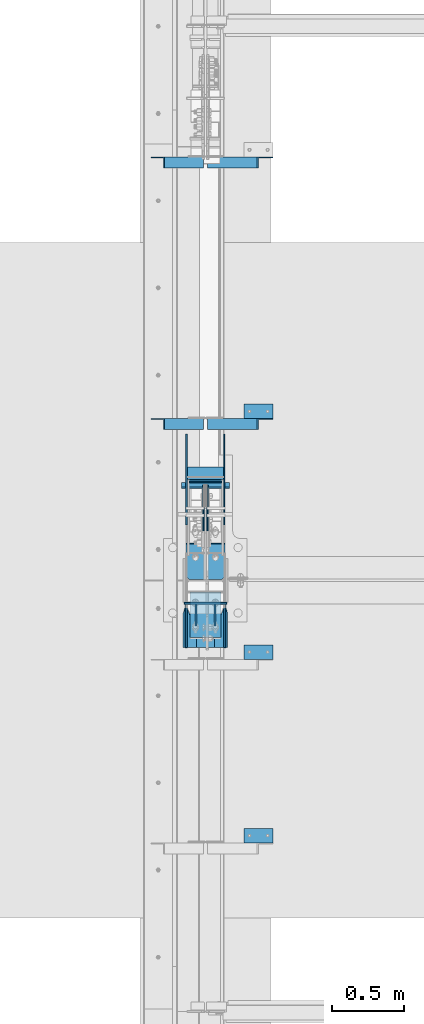
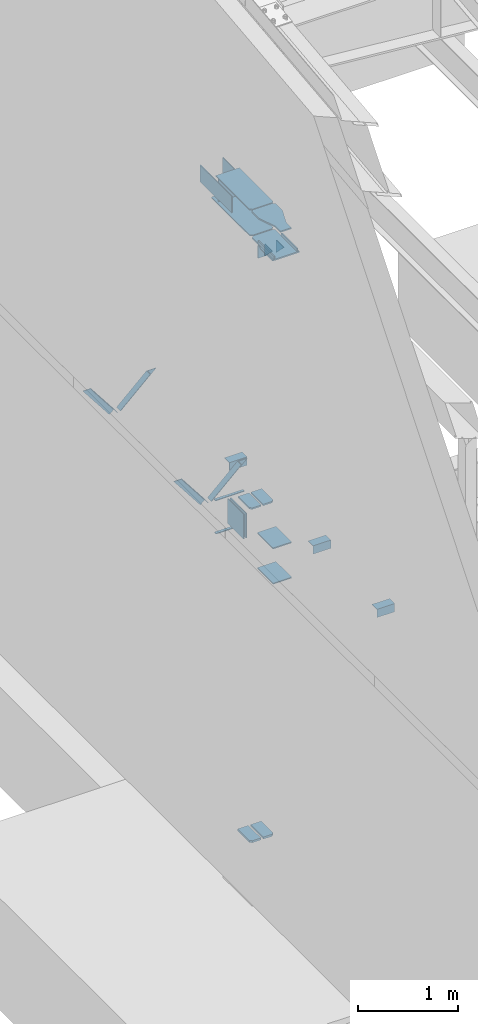
# One storey, part 811 of 1179: 25 beams, 4 members, 16 elements without a shape of their own.
"""IFC2X3 building model written with IfcOpenShell, lengths in millimetres."""

from ifc_helpers import new_model, si_unit, frame, origin_with_axes, place, context, subcontext, project, spatial, faceted_brep, material, type_object, element, aggregate, save


model = new_model("IFC2X3")

# Units and contexts
model_context = context("Model", 3, precision=1e-05, world=origin_with_axes())
body_context = subcontext(model_context, "Body", "Model", "MODEL_VIEW")
ifc_project = project(units=[si_unit("LENGTHUNIT", "METRE", prefix="MILLI"), si_unit("AREAUNIT", "SQUARE_METRE"), si_unit("VOLUMEUNIT", "CUBIC_METRE"), si_unit("MASSUNIT", "GRAM", prefix="KILO"), si_unit("TIMEUNIT", "SECOND"), si_unit("PLANEANGLEUNIT", "RADIAN"), si_unit("SOLIDANGLEUNIT", "STERADIAN"), si_unit("THERMODYNAMICTEMPERATUREUNIT", "DEGREE_CELSIUS"), si_unit("LUMINOUSINTENSITYUNIT", "LUMEN")], contexts=[model_context])

# Site, building, storey
site_placement = place(None, origin_with_axes())
site = spatial("IfcSite", under=ifc_project, at=site_placement, CompositionType="ELEMENT")
building_placement = place(site_placement, origin_with_axes())
building = spatial("IfcBuilding", under=site, at=building_placement, Name="Undefined", CompositionType="ELEMENT")
storey_placement = place(building_placement, origin_with_axes())
storey = spatial("IfcBuildingStorey", under=building, at=storey_placement, Name="Undefined", CompositionType="ELEMENT", Elevation=0.0)

# Assembly, member
assembly_1_placement = place(storey_placement, origin_with_axes())
assembly_1 = element("IfcElementAssembly", 1, at=assembly_1_placement, inside=storey, Name="ANGLE", AssemblyPlace="NOTDEFINED", PredefinedType="RIGID_FRAME")
ifc_material_1 = material(Name="STEEL/A36")
member_type = type_object("IfcMemberType", Name="L3X3X1/4", PredefinedType="NOTDEFINED")
member_1_placement = place(assembly_1_placement, frame((472.414639168564, 14401.8, 3736.19330123132), z_axis=(0.0, -1.0, 0.0), x_axis=(0.729484494811633, 0.0, 0.683997347823379)))
member_1 = element("IfcMember", 2, at=member_1_placement, type_object=member_type, material=ifc_material_1, Name="ANGLE", ObjectType="L3X3X1/4", context=body_context, shape_type="Brep", body=[
    faceted_brep([(0.0, 38.0999999999985, -38.0999999999999), (0.0, 38.0999999999985, 38.0999999999999), (475.752341075195, 38.0999999999181, 38.1000000000004), (475.752341075195, 38.0999999999181, -38.1000000000004), (0.0, 31.75, 38.1000000000004), (482.524628360803, 31.7499999999177, 38.1000000000004), (0.0, 31.75, -31.75), (482.524628360803, 31.7499999999177, -31.75), (0.0, -38.0999999999985, -31.75), (557.019788502486, -38.1000000000854, -31.75), (0.0, -38.0999999999985, -38.0999999999999), (557.019788502486, -38.1000000000854, -38.1000000000004)], [[[0, 1, 2, 3]], [[1, 4, 5, 2]], [[4, 6, 7, 5]], [[6, 8, 9, 7]], [[8, 10, 11, 9]], [[10, 0, 3, 11]], [[5, 7, 9, 11, 3, 2]], [[10, 8, 6, 4, 1, 0]]]),
])
aggregate(assembly_1, [member_1])

assembly_2_placement = place(storey_placement, origin_with_axes())
assembly_2 = element("IfcElementAssembly", 3, at=assembly_2_placement, inside=storey, Name="ANGLE", AssemblyPlace="NOTDEFINED", PredefinedType="RIGID_FRAME")
member_2_placement = place(assembly_2_placement, frame((472.414639168564, 12573.0, 3736.19330123132), z_axis=(0.0, -1.0, 0.0), x_axis=(0.729484494811633, 0.0, 0.683997347823379)))
member_2 = element("IfcMember", 4, at=member_2_placement, type_object=member_type, material=ifc_material_1, Name="ANGLE", ObjectType="L3X3X1/4", context=body_context, shape_type="Brep", body=[
    faceted_brep([(0.0, 38.0999999999985, -38.0999999999999), (0.0, 38.0999999999985, 38.0999999999999), (475.752341075195, 38.0999999999181, 38.1000000000004), (475.752341075195, 38.0999999999181, -38.1000000000004), (0.0, 31.75, 38.1000000000004), (482.524628360803, 31.7499999999177, 38.1000000000004), (0.0, 31.75, -31.75), (482.524628360803, 31.7499999999177, -31.75), (0.0, -38.0999999999985, -31.75), (557.019788502486, -38.1000000000854, -31.75), (0.0, -38.0999999999985, -38.0999999999999), (557.019788502486, -38.1000000000854, -38.1000000000004)], [[[0, 1, 2, 3]], [[1, 4, 5, 2]], [[4, 6, 7, 5]], [[6, 8, 9, 7]], [[8, 10, 11, 9]], [[10, 0, 3, 11]], [[5, 7, 9, 11, 3, 2]], [[10, 8, 6, 4, 1, 0]]]),
])
aggregate(assembly_2, [member_2])

assembly_3_placement = place(storey_placement, origin_with_axes())
assembly_3 = element("IfcElementAssembly", 5, at=assembly_3_placement, inside=storey, Name="ANGLE", AssemblyPlace="NOTDEFINED", PredefinedType="RIGID_FRAME")
member_3_placement = place(assembly_3_placement, frame((80.8196258456476, 14401.8, 4125.56128839178), z_axis=(0.0, -1.0, 0.0), x_axis=(0.614083067285056, 0.0, -0.789241399366364)))
member_3 = element("IfcMember", 6, at=member_3_placement, type_object=member_type, material=ifc_material_1, Name="ANGLE", ObjectType="L3X3X1/4", context=body_context, shape_type="Brep", body=[
    faceted_brep([(59.3707492954454, 38.0999999999781, -38.1000000000004), (59.3707492954454, 38.0999999999781, 38.1000000000004), (499.083854779058, 38.0999999998585, 38.1000000000004), (499.083854779058, 38.0999999998585, -38.1000000000004), (54.4300207928691, 31.7499999999804, 38.1000000000004), (499.083854779056, 31.7499999998595, 38.1000000000004), (54.4300207928691, 31.7499999999804, -31.75), (499.083854779056, 31.7499999998595, -31.75), (0.0820072645328764, -38.0999999999945, -31.75), (499.083854779043, -38.10000000013, -31.75), (0.0820072645328764, -38.0999999999945, -38.1000000000004), (499.083854779043, -38.10000000013, -38.1000000000004)], [[[0, 1, 2, 3]], [[1, 4, 5, 2]], [[4, 6, 7, 5]], [[6, 8, 9, 7]], [[8, 10, 11, 9]], [[10, 0, 3, 11]], [[5, 7, 9, 11, 3, 2]], [[10, 8, 6, 4, 1, 0]]]),
])
aggregate(assembly_3, [member_3])

assembly_4_placement = place(storey_placement, origin_with_axes())
assembly_4 = element("IfcElementAssembly", 7, at=assembly_4_placement, inside=storey, Name="ANGLE", AssemblyPlace="NOTDEFINED", PredefinedType="RIGID_FRAME")
member_4_placement = place(assembly_4_placement, frame((80.8196258456476, 12573.0, 4125.56128839178), z_axis=(0.0, -1.0, 0.0), x_axis=(0.614083067285056, 0.0, -0.789241399366364)))
member_4 = element("IfcMember", 8, at=member_4_placement, type_object=member_type, material=ifc_material_1, Name="ANGLE", ObjectType="L3X3X1/4", context=body_context, shape_type="Brep", body=[
    faceted_brep([(59.3707492954454, 38.0999999999781, -38.1000000000004), (59.3707492954454, 38.0999999999781, 38.1000000000004), (499.083854779058, 38.0999999998585, 38.1000000000004), (499.083854779058, 38.0999999998585, -38.1000000000004), (54.4300207928691, 31.7499999999804, 38.1000000000004), (499.083854779056, 31.7499999998595, 38.1000000000004), (54.4300207928691, 31.7499999999804, -31.75), (499.083854779056, 31.7499999998595, -31.75), (0.0820072645328764, -38.0999999999945, -31.75), (499.083854779043, -38.10000000013, -31.75), (0.0820072645328764, -38.0999999999945, -38.1000000000004), (499.083854779043, -38.10000000013, -38.1000000000004)], [[[0, 1, 2, 3]], [[1, 4, 5, 2]], [[4, 6, 7, 5]], [[6, 8, 9, 7]], [[8, 10, 11, 9]], [[10, 0, 3, 11]], [[5, 7, 9, 11, 3, 2]], [[10, 8, 6, 4, 1, 0]]]),
])
aggregate(assembly_4, [member_4])

# Assembly, beams
assembly_5_placement = place(storey_placement, origin_with_axes())
assembly_5 = element("IfcElementAssembly", 9, at=assembly_5_placement, inside=storey, Name="BEAM", AssemblyPlace="NOTDEFINED", PredefinedType="RIGID_FRAME")
ifc_material_2 = material(Name="STEEL/A572-GR.50")
beam_type_1 = type_object("IfcBeamType", PredefinedType="NOTDEFINED")
beam_1_placement = place(assembly_5_placement, frame((431.800036620873, 12122.4863327342, 3678.2375), z_axis=(-1.0, 0.0, 0.0), x_axis=(0.0, 1.0, 0.0)))
beam_1 = element("IfcBeam", 10, at=beam_1_placement, type_object=beam_type_1, material=ifc_material_2, Name="PLATE", context=body_context, shape_type="Brep", body=[
    faceted_brep([(0.0, 4.76249999999982, -168.275000000001), (0.0, 4.76250000000073, 168.275), (31.75, 4.76249999999982, 168.275000000001), (31.75, 4.76249999999982, -168.275000000001), (0.0, -4.76250000000073, 168.275), (31.75, -4.76249999999982, 168.275000000001), (0.0, -4.76249999999982, -168.275000000001), (31.75, -4.76249999999982, -168.275000000001)], [[[0, 1, 2, 3]], [[1, 4, 5, 2]], [[4, 6, 7, 5]], [[6, 0, 3, 7]], [[5, 7, 3, 2]], [[6, 4, 1, 0]]]),
])
beam_2_placement = place(assembly_5_placement, frame((431.800036620873, 12133.5984303375, 4077.8905), z_axis=(-1.0, 0.0, 0.0), x_axis=(0.0, 1.0, 0.0)))
beam_2 = element("IfcBeam", 11, at=beam_2_placement, type_object=beam_type_1, material=ifc_material_2, Name="PLATE", context=body_context, shape_type="Brep", body=[
    faceted_brep([(0.0, 4.76249999999982, -168.275000000001), (0.0, 4.76250000000073, 168.275), (31.75, 4.76249999999982, 168.275000000001), (31.75, 4.76249999999982, -168.275000000001), (0.0, -4.76250000000073, 168.275), (31.75, -4.76249999999982, 168.275000000001), (0.0, -4.76249999999982, -168.275000000001), (31.75, -4.76249999999982, -168.275000000001)], [[[0, 1, 2, 3]], [[1, 4, 5, 2]], [[4, 6, 7, 5]], [[6, 0, 3, 7]], [[5, 7, 3, 2]], [[6, 4, 1, 0]]]),
])
aggregate(assembly_5, [beam_1, beam_2])

assembly_6_placement = place(storey_placement, origin_with_axes())
assembly_6 = element("IfcElementAssembly", 12, at=assembly_6_placement, inside=storey, Name="COLUMN", AssemblyPlace="NOTDEFINED", PredefinedType="RIGID_FRAME")
beam_type_2 = type_object("IfcBeamType", PredefinedType="NOTDEFINED")
beam_3_placement = place(assembly_6_placement, frame((284.162500000006, 11320.4625, 7616.82500000912), z_axis=(0.0, 0.0, 1.0), x_axis=(1.0, 0.0, 0.0)))
beam_3 = element("IfcBeam", 13, at=beam_3_placement, type_object=beam_type_2, material=ifc_material_1, Name="PLATE", context=body_context, shape_type="Brep", body=[
    faceted_brep([(-7.27595761418343e-12, 6.35000000000036, -76.1999999999971), (0.0, 6.35000000000036, 76.2000000000044), (295.274999999994, 6.34999999999854, 76.2000000000007), (295.274999999994, 6.34999999999854, -76.2000000000007), (0.0, -6.35000000000036, 76.2000000000044), (295.274999999994, -6.34999999999854, 76.2000000000007), (7.27595761418343e-12, -6.35000000000036, -76.1999999999971), (295.274999999994, -6.34999999999854, -76.2000000000007)], [[[0, 1, 2, 3]], [[1, 4, 5, 2]], [[4, 6, 7, 5]], [[6, 0, 3, 7]], [[5, 7, 3, 2]], [[6, 4, 1, 0]]]),
])
beam_type_3 = type_object("IfcBeamType", PredefinedType="NOTDEFINED")
beam_4_placement = place(assembly_6_placement, frame((505.619000000002, 11734.5860983541, 4353.49928057188), z_axis=(1.0, 0.0, 0.0), x_axis=(0.0, -1.0, 0.0)))
beam_4 = element("IfcBeam", 14, at=beam_4_placement, type_object=beam_type_3, material=ifc_material_2, Name="PLATE", context=body_context, shape_type="Brep", body=[
    faceted_brep([(247.436098354521, -9.52499999999964, 40.4809996181785), (247.436098354145, 9.52499999999964, 40.4809996181785), (225.211098339509, 9.52499999999964, 62.7065000000002), (225.211098339509, -9.52499999999964, 62.7065000000002), (6.18456397205591e-11, -9.52499999999964, -62.7065000000084), (0.0, -9.52499999999964, 62.7065000000002), (0.0, 9.52499999999964, 62.7065000000002), (6.18456397205591e-11, 9.52499999999964, -62.7065000000084), (247.436098339509, 9.52499999999964, -62.7065000000002), (247.436098339509, -9.52499999999964, -62.7065000000002)], [[[0, 1, 2, 3]], [[4, 5, 6, 7]], [[4, 7, 8, 9]], [[5, 4, 9, 0, 3]], [[6, 5, 3, 2]], [[8, 7, 6, 2, 1]], [[9, 8, 1, 0]]]),
])
beam_5_placement = place(assembly_6_placement, frame((357.981000000002, 11734.5860983541, 4353.49928057188), z_axis=(-1.0, 0.0, 0.0), x_axis=(0.0, -1.0, 0.0)))
beam_5 = element("IfcBeam", 15, at=beam_5_placement, type_object=beam_type_3, material=ifc_material_2, Name="PLATE", context=body_context, shape_type="Brep", body=[
    faceted_brep([(247.436098354521, -9.52499999999964, 40.4809996181785), (247.436098354145, 9.52499999999964, 40.4809996181785), (225.211098339509, 9.52499999999964, 62.7065000000002), (225.211098339509, -9.52499999999964, 62.7065000000002), (6.18456397205591e-11, -9.52499999999964, -62.7065000000084), (0.0, -9.52499999999964, 62.7065000000002), (0.0, 9.52499999999964, 62.7065000000002), (6.18456397205591e-11, 9.52499999999964, -62.7065000000084), (247.436098339509, 9.52499999999964, -62.7065000000002), (247.436098339509, -9.52499999999964, -62.7065000000002)], [[[0, 1, 2, 3]], [[4, 5, 6, 7]], [[4, 7, 8, 9]], [[5, 4, 9, 0, 3]], [[6, 5, 3, 2]], [[8, 7, 6, 2, 1]], [[9, 8, 1, 0]]]),
])
beam_type_4 = type_object("IfcBeamType", PredefinedType="NOTDEFINED")
beam_6_placement = place(assembly_6_placement, frame((431.800000000002, 11398.2499999514, 3676.64999999946), z_axis=(-1.0, 0.0, 0.0), x_axis=(0.0, -1.0, 0.0)))
beam_6 = element("IfcBeam", 16, at=beam_6_placement, type_object=beam_type_4, material=ifc_material_2, Name="PLATE", context=body_context, shape_type="Brep", body=[
    faceted_brep([(0.0, 6.35000000000036, -107.949999999997), (0.0, 6.35000000000036, 107.949999999997), (317.5, 6.35000000000036, 107.949999999997), (317.5, 6.35000000000036, -107.949999999997), (0.0, -6.35000000000036, 107.949999999997), (317.5, -6.35000000000036, 107.949999999997), (0.0, -6.35000000000036, -107.949999999997), (317.5, -6.35000000000036, -107.949999999997)], [[[0, 1, 2, 3]], [[1, 4, 5, 2]], [[4, 6, 7, 5]], [[6, 0, 3, 7]], [[5, 7, 3, 2]], [[6, 4, 1, 0]]]),
])
beam_7_placement = place(assembly_6_placement, frame((431.800000000002, 11398.2499999514, 4108.44999999946), z_axis=(-1.0, 0.0, 0.0), x_axis=(0.0, -1.0, 0.0)))
beam_7 = element("IfcBeam", 17, at=beam_7_placement, type_object=beam_type_4, material=ifc_material_2, Name="PLATE", context=body_context, shape_type="Brep", body=[
    faceted_brep([(0.0, 6.35000000000036, -107.949999999997), (0.0, 6.35000000000036, 107.949999999997), (317.5, 6.35000000000036, 107.949999999997), (317.5, 6.35000000000036, -107.949999999997), (0.0, -6.35000000000036, 107.949999999997), (317.5, -6.35000000000036, 107.949999999997), (0.0, -6.35000000000036, -107.949999999997), (317.5, -6.35000000000036, -107.949999999997)], [[[0, 1, 2, 3]], [[1, 4, 5, 2]], [[4, 6, 7, 5]], [[6, 0, 3, 7]], [[5, 7, 3, 2]], [[6, 4, 1, 0]]]),
])

# Assembly, beam
assembly_7_placement = place(storey_placement, origin_with_axes())
assembly_7 = element("IfcElementAssembly", 18, at=assembly_7_placement, inside=storey, Name="ANGLE", AssemblyPlace="NOTDEFINED", PredefinedType="RIGID_FRAME")
beam_type_5 = type_object("IfcBeamType", Name="L4X4X1/4", PredefinedType="NOTDEFINED")
beam_8_placement = place(assembly_7_placement, frame((701.59635534156, 10979.15, 4051.3), z_axis=(0.0, 0.0, -1.0), x_axis=(1.0, 0.0, 0.0)))
beam_8 = element("IfcBeam", 19, at=beam_8_placement, type_object=beam_type_5, material=ifc_material_1, Name="ANGLE", ObjectType="L4X4X1/4", context=body_context, shape_type="Brep", body=[
    faceted_brep([(1.90993887372315e-11, 50.8000000000002, -50.8000000000002), (1.90993887372315e-11, 50.8000000000002, 50.8000000000002), (203.200000000001, 50.7999999999993, 50.8000000000002), (203.200000000001, 50.7999999999993, -50.8000000000002), (0.0, 44.4500000000007, 50.8000000000002), (203.200000000001, 44.4500000000007, 50.8000000000002), (0.0, 44.4500000000007, -44.4499999999998), (203.200000000001, 44.4500000000007, -44.4499999999998), (0.0, -50.7999999999993, -44.4499999999998), (203.200000000001, -50.7999999999993, -44.4499999999998), (-1.81898940354586e-11, -50.7999999999997, -50.8000000000002), (203.200000000001, -50.7999999999993, -50.8000000000002)], [[[0, 1, 2, 3]], [[1, 4, 5, 2]], [[4, 6, 7, 5]], [[6, 8, 9, 7]], [[8, 10, 11, 9]], [[10, 0, 3, 11]], [[5, 7, 9, 11, 3, 2]], [[10, 8, 6, 4, 1, 0]]]),
])
aggregate(assembly_7, [beam_8])

assembly_8_placement = place(storey_placement, origin_with_axes())
assembly_8 = element("IfcElementAssembly", 20, at=assembly_8_placement, inside=storey, Name="ANGLE", AssemblyPlace="NOTDEFINED", PredefinedType="RIGID_FRAME")
beam_9_placement = place(assembly_8_placement, frame((701.59635534156, 9695.65999128227, 4051.3), z_axis=(0.0, 0.0, -1.0), x_axis=(1.0, 0.0, 0.0)))
beam_9 = element("IfcBeam", 21, at=beam_9_placement, type_object=beam_type_5, material=ifc_material_1, Name="ANGLE", ObjectType="L4X4X1/4", context=body_context, shape_type="Brep", body=[
    faceted_brep([(1.90993887372315e-11, 50.8000000000002, -50.8000000000002), (1.90993887372315e-11, 50.8000000000002, 50.8000000000002), (203.200000000001, 50.7999999999993, 50.8000000000002), (203.200000000001, 50.7999999999993, -50.8000000000002), (0.0, 44.4500000000007, 50.8000000000002), (203.200000000001, 44.4500000000007, 50.8000000000002), (0.0, 44.4500000000007, -44.4499999999998), (203.200000000001, 44.4500000000007, -44.4499999999998), (0.0, -50.7999999999993, -44.4499999999998), (203.200000000001, -50.7999999999993, -44.4499999999998), (-1.81898940354586e-11, -50.7999999999997, -50.8000000000002), (203.200000000001, -50.7999999999993, -50.8000000000002)], [[[0, 1, 2, 3]], [[1, 4, 5, 2]], [[4, 6, 7, 5]], [[6, 8, 9, 7]], [[8, 10, 11, 9]], [[10, 0, 3, 11]], [[5, 7, 9, 11, 3, 2]], [[10, 8, 6, 4, 1, 0]]]),
])
aggregate(assembly_8, [beam_9])

assembly_9_placement = place(storey_placement, origin_with_axes())
assembly_9 = element("IfcElementAssembly", 22, at=assembly_9_placement, inside=storey, Name="ANGLE", AssemblyPlace="NOTDEFINED", PredefinedType="RIGID_FRAME")
beam_10_placement = place(assembly_9_placement, frame((701.596355341562, 12661.9, 4051.3), z_axis=(0.0, 0.0, -1.0), x_axis=(1.0, 0.0, 0.0)))
beam_10 = element("IfcBeam", 23, at=beam_10_placement, type_object=beam_type_5, material=ifc_material_1, Name="ANGLE", ObjectType="L4X4X1/4", context=body_context, shape_type="Brep", body=[
    faceted_brep([(1.90993887372315e-11, 50.8000000000002, -50.8000000000002), (1.90993887372315e-11, 50.8000000000002, 50.8000000000002), (203.200000000001, 50.7999999999993, 50.8000000000002), (203.200000000001, 50.7999999999993, -50.8000000000002), (0.0, 44.4500000000007, 50.8000000000002), (203.200000000001, 44.4500000000007, 50.8000000000002), (0.0, 44.4500000000007, -44.4499999999998), (203.200000000001, 44.4500000000007, -44.4499999999998), (0.0, -50.7999999999993, -44.4499999999998), (203.200000000001, -50.7999999999993, -44.4499999999998), (-1.81898940354586e-11, -50.7999999999997, -50.8000000000002), (203.200000000001, -50.7999999999993, -50.8000000000002)], [[[0, 1, 2, 3]], [[1, 4, 5, 2]], [[4, 6, 7, 5]], [[6, 8, 9, 7]], [[8, 10, 11, 9]], [[10, 0, 3, 11]], [[5, 7, 9, 11, 3, 2]], [[10, 8, 6, 4, 1, 0]]]),
])
aggregate(assembly_9, [beam_10])

assembly_10_placement = place(storey_placement, origin_with_axes())
assembly_10 = element("IfcElementAssembly", 24, at=assembly_10_placement, inside=storey, Name="PLATE", AssemblyPlace="NOTDEFINED", PredefinedType="RIGID_FRAME")
beam_type_6 = type_object("IfcBeamType", PredefinedType="NOTDEFINED")
beam_11_placement = place(assembly_10_placement, frame((563.562500000004, 11867.9751974615, 7861.3), z_axis=(0.0, 0.0, 1.0), x_axis=(0.0, 1.0, 0.0)))
beam_11 = element("IfcBeam", 25, at=beam_11_placement, type_object=beam_type_6, material=ifc_material_2, Name="PLATE", context=body_context, shape_type="Brep", body=[
    faceted_brep([(0.0, 4.76250000000073, -101.6), (0.0, 4.76250000000073, 101.6), (635.0, 4.76250000000073, 101.6), (635.0, 4.76250000000073, -101.6), (0.0, -4.76250000000073, 101.6), (635.0, -4.76250000000073, 101.6), (0.0, -4.76250000000073, -101.6), (635.0, -4.76250000000073, -101.6)], [[[0, 1, 2, 3]], [[1, 4, 5, 2]], [[4, 6, 7, 5]], [[6, 0, 3, 7]], [[5, 7, 3, 2]], [[6, 4, 1, 0]]]),
])
aggregate(assembly_10, [beam_11])

assembly_11_placement = place(storey_placement, origin_with_axes())
assembly_11 = element("IfcElementAssembly", 26, at=assembly_11_placement, inside=storey, Name="PLATE", AssemblyPlace="NOTDEFINED", PredefinedType="RIGID_FRAME")
beam_12_placement = place(assembly_11_placement, frame((300.037500000002, 11867.9751974615, 7861.3), z_axis=(0.0, 0.0, 1.0), x_axis=(0.0, 1.0, 0.0)))
beam_12 = element("IfcBeam", 27, at=beam_12_placement, type_object=beam_type_6, material=ifc_material_2, Name="PLATE", context=body_context, shape_type="Brep", body=[
    faceted_brep([(0.0, 4.76250000000073, -101.6), (0.0, 4.76250000000073, 101.6), (635.0, 4.76250000000073, 101.6), (635.0, 4.76250000000073, -101.6), (0.0, -4.76250000000073, 101.6), (635.0, -4.76250000000073, 101.6), (0.0, -4.76250000000073, -101.6), (635.0, -4.76250000000073, -101.6)], [[[0, 1, 2, 3]], [[1, 4, 5, 2]], [[4, 6, 7, 5]], [[6, 0, 3, 7]], [[5, 7, 3, 2]], [[6, 4, 1, 0]]]),
])
aggregate(assembly_11, [beam_12])

# Beam
beam_type_7 = type_object("IfcBeamType", PredefinedType="NOTDEFINED")
beam_13_placement = place(assembly_6_placement, frame((317.5, 12168.0126974615, 7861.3), z_axis=(0.0, 0.0, 1.0), x_axis=(1.0, 0.0, 0.0)))
beam_13 = element("IfcBeam", 28, at=beam_13_placement, type_object=beam_type_7, material=ifc_material_2, Name="PLATE", context=body_context, shape_type="Brep", body=[
    faceted_brep([(0.0, 4.76250000000073, -152.4), (0.0, 4.76250000000073, 152.4), (228.600000000002, 4.76250000000073, 152.4), (228.600000000002, 4.76250000000073, -152.4), (0.0, -4.76250000000073, 152.4), (228.600000000002, -4.76250000000073, 152.4), (0.0, -4.76250000000073, -152.4), (228.600000000002, -4.76250000000073, -152.4)], [[[0, 1, 2, 3]], [[1, 4, 5, 2]], [[4, 6, 7, 5]], [[6, 0, 3, 7]], [[5, 7, 3, 2]], [[6, 4, 1, 0]]]),
])

beam_type_8 = type_object("IfcBeamType", PredefinedType="NOTDEFINED")
beam_14_placement = place(assembly_6_placement, frame((431.799999999999, 12274.3751974615, 7702.55), z_axis=(-1.0, 0.0, 0.0), x_axis=(0.0, -1.0, 0.0)))
beam_14 = element("IfcBeam", 29, at=beam_14_placement, type_object=beam_type_8, material=ifc_material_2, Name="PLATE", context=body_context, shape_type="Brep", body=[
    faceted_brep([(765.000197461464, 6.35000000000036, -136.525000000001), (787.225197461465, 6.35000000000036, -114.299999999999), (787.225197461465, -6.35000000000036, -114.299999999999), (765.000197461464, -6.35000000000036, -136.525000000001), (787.225197461465, 6.35000000000036, 114.299999999999), (765.000197461464, 6.35000000000036, 136.525000000001), (765.000197461464, -6.35000000000036, 136.525000000001), (787.225197461465, -6.35000000000036, 114.299999999999), (0.0, 6.35000000000036, -136.525000000001), (0.0, 6.35000000000036, 136.525000000001), (0.0, -6.35000000000036, 136.525000000001), (0.0, -6.35000000000036, -136.525000000001)], [[[0, 1, 2, 3]], [[4, 5, 6, 7]], [[8, 9, 5, 4, 1, 0]], [[9, 10, 6, 5]], [[7, 6, 10, 11, 3, 2]], [[11, 8, 0, 3]], [[4, 7, 2, 1]], [[11, 10, 9, 8]]]),
])

beam_15_placement = place(assembly_6_placement, frame((431.799999999999, 12185.4751974615, 8020.05), z_axis=(-1.0, 0.0, 0.0), x_axis=(0.0, -1.0, 0.0)))
beam_15 = element("IfcBeam", 30, at=beam_15_placement, type_object=beam_type_8, material=ifc_material_2, Name="PLATE", context=body_context, shape_type="Brep", body=[
    faceted_brep([(676.100197461472, 6.35000000000036, -136.525000000001), (698.325197461472, 6.35000000000036, -114.299999999999), (698.325197461472, -6.35000000000036, -114.299999999999), (676.100197461472, -6.35000000000036, -136.525000000001), (698.325197461472, 6.35000000000036, 114.299999999999), (676.100197461472, 6.35000000000036, 136.525000000001), (676.100197461472, -6.35000000000036, 136.525000000001), (698.325197461472, -6.35000000000036, 114.299999999999), (0.0, 6.35000000000036, -136.525000000001), (0.0, 6.35000000000036, 136.525000000001), (0.0, -6.35000000000036, 136.525000000001), (0.0, -6.35000000000036, -136.525000000001)], [[[0, 1, 2, 3]], [[4, 5, 6, 7]], [[8, 9, 5, 4, 1, 0]], [[9, 10, 6, 5]], [[7, 6, 10, 11, 3, 2]], [[11, 8, 0, 3]], [[4, 7, 2, 1]], [[11, 10, 9, 8]]]),
])

# Assembly, beam
assembly_12_placement = place(storey_placement, origin_with_axes())
assembly_12 = element("IfcElementAssembly", 31, at=assembly_12_placement, inside=storey, Name="PLATE", AssemblyPlace="NOTDEFINED", PredefinedType="RIGID_FRAME")
beam_type_9 = type_object("IfcBeamType", PredefinedType="NOTDEFINED")
beam_16_placement = place(assembly_12_placement, frame((356.3935, 11742.2619188609, 267.318748335632), z_axis=(-1.0, 0.0, 0.0), x_axis=(0.0, -1.0, 0.0)))
beam_16 = element("IfcBeam", 32, at=beam_16_placement, type_object=beam_type_9, material=ifc_material_2, Name="PLATE", context=body_context, shape_type="Brep", body=[
    faceted_brep([(255.111918860846, 12.7, 38.8940000000002), (232.886918860846, 12.7, 61.1189999999988), (232.886918860846, -12.7, 61.1189999999988), (255.111918860846, -12.7, 38.8940000000002), (255.111918860846, 12.7, -61.1189999999988), (0.0, 12.7, -61.1189999999988), (0.0, 12.7, 61.1189999999988), (0.0, -12.7, 61.1189999999988), (0.0, -12.7, -61.1189999999988), (255.111918860846, -12.7, -61.1189999999988)], [[[0, 1, 2, 3]], [[4, 5, 6, 1, 0]], [[6, 7, 2, 1]], [[7, 8, 9, 3, 2]], [[8, 5, 4, 9]], [[9, 4, 0, 3]], [[8, 7, 6, 5]]]),
])
aggregate(assembly_12, [beam_16])

assembly_13_placement = place(storey_placement, origin_with_axes())
assembly_13 = element("IfcElementAssembly", 33, at=assembly_13_placement, inside=storey, Name="PLATE", AssemblyPlace="NOTDEFINED", PredefinedType="RIGID_FRAME")
beam_17_placement = place(assembly_13_placement, frame((507.2065, 11742.2619188609, 267.318748335632), z_axis=(1.0, 0.0, 0.0), x_axis=(0.0, -1.0, 0.0)))
beam_17 = element("IfcBeam", 34, at=beam_17_placement, type_object=beam_type_9, material=ifc_material_2, Name="PLATE", context=body_context, shape_type="Brep", body=[
    faceted_brep([(255.111918860846, 12.7, 38.8940000000002), (232.886918860846, 12.7, 61.1189999999988), (232.886918860846, -12.7, 61.1189999999988), (255.111918860846, -12.7, 38.8940000000002), (255.111918860846, 12.7, -61.1189999999988), (0.0, 12.7, -61.1189999999988), (0.0, 12.7, 61.1189999999988), (0.0, -12.7, 61.1189999999988), (0.0, -12.7, -61.1189999999988), (255.111918860846, -12.7, -61.1189999999988)], [[[0, 1, 2, 3]], [[4, 5, 6, 1, 0]], [[6, 7, 2, 1]], [[7, 8, 9, 3, 2]], [[8, 5, 4, 9]], [[9, 4, 0, 3]], [[8, 7, 6, 5]]]),
])
aggregate(assembly_13, [beam_17])

assembly_14_placement = place(storey_placement, origin_with_axes())
assembly_14 = element("IfcElementAssembly", 35, at=assembly_14_placement, inside=storey, Name="PLATE", AssemblyPlace="NOTDEFINED", PredefinedType="RIGID_FRAME")
beam_type_10 = type_object("IfcBeamType", PredefinedType="NOTDEFINED")
beam_18_placement = place(assembly_14_placement, frame((417.512500000002, 12146.2991796213, 3892.55), z_axis=(0.0, 0.0, -1.0), x_axis=(0.0, -1.0, 0.0)))
beam_18 = element("IfcBeam", 36, at=beam_18_placement, type_object=beam_type_10, material=ifc_material_2, Name="PLATE", context=body_context, shape_type="Brep", body=[
    faceted_brep([(0.0, 4.76250000000073, -152.4), (0.0, 4.76250000000073, 152.4), (317.5, 4.76250000000073, 152.4), (317.5, 4.76250000000073, -152.4), (0.0, -4.76250000000073, 152.4), (317.5, -4.76250000000073, 152.4), (0.0, -4.76250000000073, -152.4), (317.5, -4.76250000000073, -152.4)], [[[0, 1, 2, 3]], [[1, 4, 5, 2]], [[4, 6, 7, 5]], [[6, 0, 3, 7]], [[5, 7, 3, 2]], [[6, 4, 1, 0]]]),
])
aggregate(assembly_14, [beam_18])

assembly_15_placement = place(storey_placement, origin_with_axes())
assembly_15 = element("IfcElementAssembly", 37, at=assembly_15_placement, inside=storey, Name="PLATE", AssemblyPlace="NOTDEFINED", PredefinedType="RIGID_FRAME")
beam_19_placement = place(assembly_15_placement, frame((446.087213611823, 11828.7991796213, 3892.55), z_axis=(0.0, 0.0, -1.0), x_axis=(0.0, 1.0, 0.0)))
beam_19 = element("IfcBeam", 38, at=beam_19_placement, type_object=beam_type_10, material=ifc_material_2, Name="PLATE", context=body_context, shape_type="Brep", body=[
    faceted_brep([(0.0, 4.76250000000073, -152.4), (0.0, 4.76250000000073, 152.4), (317.5, 4.76250000000073, 152.4), (317.5, 4.76250000000073, -152.4), (0.0, -4.76250000000073, 152.4), (317.5, -4.76250000000073, 152.4), (0.0, -4.76250000000073, -152.4), (317.5, -4.76250000000073, -152.4)], [[[0, 1, 2, 3]], [[1, 4, 5, 2]], [[4, 6, 7, 5]], [[6, 0, 3, 7]], [[5, 7, 3, 2]], [[6, 4, 1, 0]]]),
])
aggregate(assembly_15, [beam_19])

# Beam
beam_type_11 = type_object("IfcBeamType", PredefinedType="NOTDEFINED")
beam_20_placement = place(assembly_6_placement, frame((296.862500000007, 11009.3125, 7727.95000000912), z_axis=(0.0, 0.0, 1.0), x_axis=(0.0, 1.0, 0.0)))
beam_20 = element("IfcBeam", 39, at=beam_20_placement, type_object=beam_type_11, material=ifc_material_1, Name="PLATE", context=body_context, shape_type="Brep", body=[
    faceted_brep([(0.0, 6.34999999999854, -19.0499999999993), (0.0, 6.35000000000036, 19.0499999999993), (317.5, 6.34999999999854, 19.0499999999993), (317.5, 6.34999999999854, -19.0499999999993), (0.0, -6.35000000000036, 19.0499999999993), (317.5, -6.34999999999854, 19.0499999999993), (0.0, -6.34999999999854, -19.0499999999993), (317.5, -6.34999999999854, -19.0499999999993)], [[[0, 1, 2, 3]], [[1, 4, 5, 2]], [[4, 6, 7, 5]], [[6, 0, 3, 7]], [[5, 7, 3, 2]], [[6, 4, 1, 0]]]),
])

beam_21_placement = place(assembly_6_placement, frame((566.737500000005, 11009.3125, 7727.95000000912), z_axis=(0.0, 0.0, 1.0), x_axis=(0.0, 1.0, 0.0)))
beam_21 = element("IfcBeam", 40, at=beam_21_placement, type_object=beam_type_11, material=ifc_material_1, Name="PLATE", context=body_context, shape_type="Brep", body=[
    faceted_brep([(0.0, 6.34999999999854, -19.0499999999993), (0.0, 6.35000000000036, 19.0499999999993), (317.5, 6.34999999999854, 19.0499999999993), (317.5, 6.34999999999854, -19.0499999999993), (0.0, -6.35000000000036, 19.0499999999993), (317.5, -6.34999999999854, 19.0499999999993), (0.0, -6.34999999999854, -19.0499999999993), (317.5, -6.34999999999854, -19.0499999999993)], [[[0, 1, 2, 3]], [[1, 4, 5, 2]], [[4, 6, 7, 5]], [[6, 0, 3, 7]], [[5, 7, 3, 2]], [[6, 4, 1, 0]]]),
])

beam_type_12 = type_object("IfcBeamType", PredefinedType="NOTDEFINED")
beam_22_placement = place(assembly_6_placement, frame((365.125000000004, 11161.7125, 7616.82500000912), z_axis=(0.0, 0.0, 1.0), x_axis=(0.0, 1.0, 0.0)))
beam_22 = element("IfcBeam", 41, at=beam_22_placement, type_object=beam_type_12, material=ifc_material_1, Name="PLATE", context=body_context, shape_type="Brep", body=[
    faceted_brep([(152.4, -4.76249999999709, 76.2), (152.4, -4.76249999999709, -76.2), (152.4, 4.76249999999709, -76.2), (152.4, 4.76249999999709, 76.2), (0.0, 4.76249999999982, 76.1999999999971), (0.0, -4.76249999999982, 76.1999999999971)], [[[0, 1, 2, 3]], [[3, 2, 4]], [[4, 5, 0, 3]], [[0, 5, 1]], [[4, 2, 1, 5]]]),
])

beam_23_placement = place(assembly_6_placement, frame((498.475000000002, 11161.7125, 7616.82500000912), z_axis=(0.0, 0.0, 1.0), x_axis=(0.0, 1.0, 0.0)))
beam_23 = element("IfcBeam", 42, at=beam_23_placement, type_object=beam_type_12, material=ifc_material_1, Name="PLATE", context=body_context, shape_type="Brep", body=[
    faceted_brep([(152.4, -4.76249999999709, 76.2), (152.4, -4.76249999999709, -76.2), (152.4, 4.76249999999709, -76.2), (152.4, 4.76249999999709, 76.2), (0.0, 4.76249999999982, 76.1999999999971), (0.0, -4.76249999999982, 76.1999999999971)], [[[0, 1, 2, 3]], [[3, 2, 4]], [[4, 5, 0, 3]], [[0, 5, 1]], [[4, 2, 1, 5]]]),
])

beam_type_13 = type_object("IfcBeamType", PredefinedType="NOTDEFINED")
beam_24_placement = place(assembly_6_placement, frame((431.800000000003, 11009.3125, 7700.96250000912), z_axis=(1.0, 0.0, 0.0), x_axis=(0.0, 1.0, 0.0)))
beam_24 = element("IfcBeam", 43, at=beam_24_placement, type_object=beam_type_13, material=ifc_material_1, Name="PLATE", context=body_context, shape_type="Brep", body=[
    faceted_brep([(465.137499999997, -7.9375, -114.300000762945), (442.912499999999, -7.9375, -136.525000762944), (442.912500000006, 7.9375, -136.525000762944), (465.137500000004, 7.9375, -114.300000762945), (465.137500000004, 7.9375, 114.300000762938), (442.912500000006, 7.9375, 136.525000762937), (442.912499999999, -7.9375, 136.525000762937), (465.137499999997, -7.9375, 114.300000762938), (241.300006103491, -7.9375, -155.575000000001), (241.300006103491, 7.9375, -155.575000000001), (304.799990844724, 7.9375, -136.525000762944), (304.799990844724, -7.9375, -136.525000762944), (0.0, -7.9375, -155.575000000001), (0.0, -7.9375, 155.575000000001), (0.0, 7.9375, 155.575000000001), (0.0, 7.9375, -155.575000000001), (241.300006103513, -7.9375, 155.575000000001), (241.300006103513, 7.9375, 155.575000000001), (304.799990844724, -7.9375, 136.525000762937), (304.799990844724, 7.9375, 136.525000762937)], [[[0, 1, 2, 3]], [[4, 5, 6, 7]], [[8, 9, 10, 11]], [[11, 10, 2, 1]], [[12, 13, 14, 15]], [[14, 13, 16, 17]], [[18, 19, 17, 16]], [[19, 18, 6, 5]], [[4, 7, 0, 3]], [[10, 9, 15, 14, 17, 19, 5, 4, 3, 2]], [[12, 15, 9, 8]], [[7, 6, 18, 16, 13, 12, 8, 11, 1, 0]]]),
])

aggregate(assembly_6, [beam_13, beam_14, beam_15, beam_4, beam_5, beam_20, beam_22, beam_21, beam_23, beam_24, beam_3, beam_6, beam_7])

# Assembly, beam
assembly_16_placement = place(storey_placement, origin_with_axes())
assembly_16 = element("IfcElementAssembly", 44, at=assembly_16_placement, inside=storey, Name="PLATE", AssemblyPlace="NOTDEFINED", PredefinedType="RIGID_FRAME")
beam_type_14 = type_object("IfcBeamType", PredefinedType="NOTDEFINED")
beam_25_placement = place(assembly_16_placement, frame((431.800000000003, 11009.3125, 8021.63750000912), z_axis=(1.0, 0.0, 0.0), x_axis=(0.0, 1.0, 0.0)))
beam_25 = element("IfcBeam", 45, at=beam_25_placement, type_object=beam_type_14, material=ifc_material_1, Name="PLATE", context=body_context, shape_type="Brep", body=[
    faceted_brep([(465.137499999997, -7.9375, -114.300000762945), (442.912499999999, -7.9375, -136.525000762944), (442.912500000006, 7.9375, -136.525000762944), (465.137500000004, 7.9375, -114.300000762945), (465.137500000004, 7.9375, 114.300000762938), (442.912500000006, 7.9375, 136.525000762937), (442.912499999999, -7.9375, 136.525000762937), (465.137499999997, -7.9375, 114.300000762938), (97.1744871646697, -7.9375, 63.4999984741225), (97.1744871646697, 7.9375, 63.4999984741225), (0.0, 7.9375, 63.5), (0.0, -7.9375, 63.5), (99.3625358760146, -7.9375, 63.5944172169256), (99.3625358760146, 7.9375, 63.5944172169256), (101.534317436837, -7.9375, 63.8769714847585), (101.534317436837, 7.9375, 63.8769714847585), (103.673685635511, -7.9375, 64.3455606147181), (103.673685635511, 7.9375, 64.3455606147181), (105.764735239063, -7.9375, 64.9967008589738), (105.764735239063, 7.9375, 64.9967008589738), (304.799990844724, -7.9375, 136.525000762937), (304.799990844724, 7.9375, 136.525000762937), (0.0, -7.9375, -63.5), (0.0, 7.9375, -63.5), (97.1744871646697, 7.9375, -63.5), (97.1744871646697, -7.9375, -63.5), (99.3625358760146, 7.9375, -63.5944187428031), (99.3625358760146, -7.9375, -63.5944187428031), (101.534317436837, 7.9375, -63.876973010636), (101.534317436837, -7.9375, -63.876973010636), (103.673685635511, 7.9375, -64.3455621405956), (103.673685635511, -7.9375, -64.3455621405956), (105.764735239063, 7.9375, -64.9967023848512), (105.764735239063, -7.9375, -64.9967023848512), (304.799990844724, -7.9375, -136.525000762944), (304.799990844724, 7.9375, -136.525000762944)], [[[0, 1, 2, 3]], [[4, 5, 6, 7]], [[8, 9, 10, 11]], [[12, 13, 9, 8]], [[14, 15, 13, 12]], [[16, 17, 15, 14]], [[18, 19, 17, 16]], [[20, 21, 19, 18]], [[22, 23, 24, 25]], [[25, 24, 26, 27]], [[27, 26, 28, 29]], [[29, 28, 30, 31]], [[31, 30, 32, 33]], [[34, 33, 32, 35]], [[34, 35, 2, 1]], [[4, 7, 0, 3]], [[7, 6, 20, 18, 16, 14, 12, 8, 11, 22, 25, 27, 29, 31, 33, 34, 1, 0]], [[22, 11, 10, 23]], [[35, 32, 30, 28, 26, 24, 23, 10, 9, 13, 15, 17, 19, 21, 5, 4, 3, 2]], [[21, 20, 6, 5]]]),
])
aggregate(assembly_16, [beam_25])

save(model, "model.ifc")
